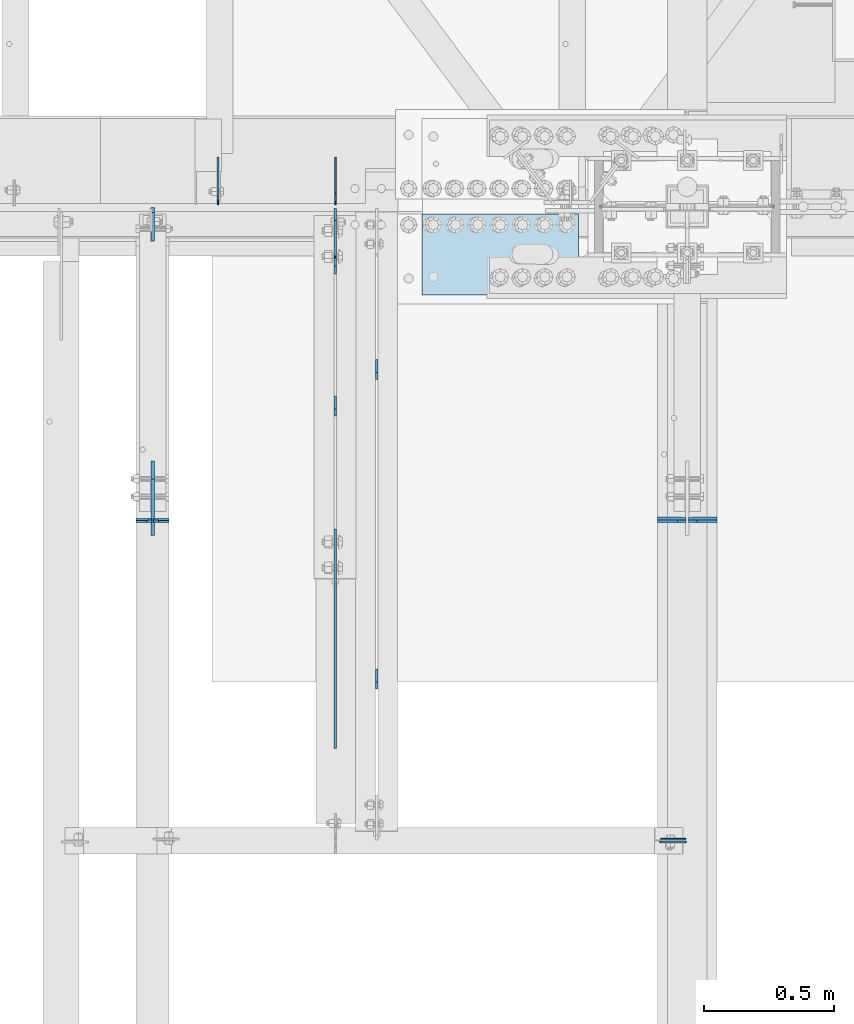
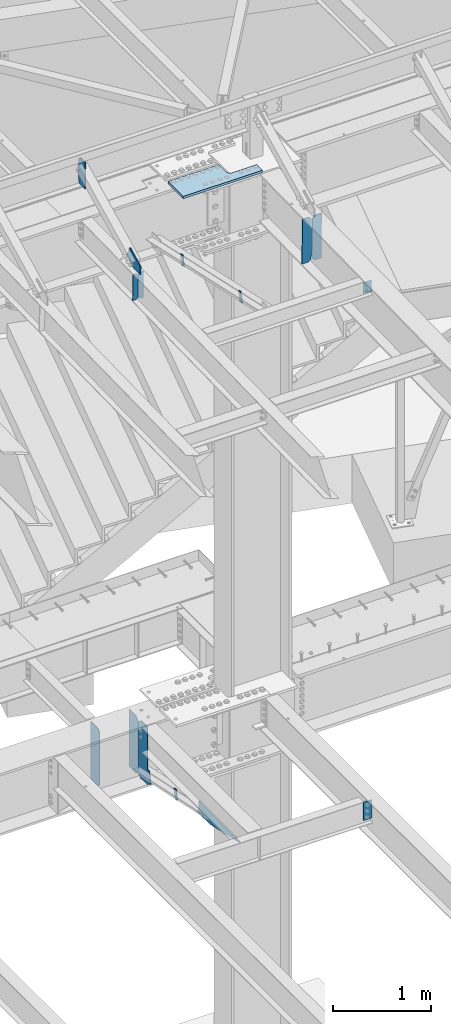
# One storey, part 1638 of 1763: 16 plates, 9 elements without a shape of their own.
"""IFC2X3 building model written with IfcOpenShell, lengths in millimetres."""

from ifc_helpers import new_model, si_unit, frame, origin_with_axes, place, context, subcontext, project, spatial, faceted_brep, material, type_object, element, aggregate, save


model = new_model("IFC2X3")

# Units and contexts
model_context = context("Model", 3, precision=1e-05, world=origin_with_axes())
body_context = subcontext(model_context, "Body", "Model", "MODEL_VIEW")
ifc_project = project(units=[si_unit("LENGTHUNIT", "METRE", prefix="MILLI"), si_unit("AREAUNIT", "SQUARE_METRE"), si_unit("VOLUMEUNIT", "CUBIC_METRE"), si_unit("MASSUNIT", "GRAM", prefix="KILO"), si_unit("TIMEUNIT", "SECOND"), si_unit("PLANEANGLEUNIT", "RADIAN"), si_unit("SOLIDANGLEUNIT", "STERADIAN"), si_unit("THERMODYNAMICTEMPERATUREUNIT", "DEGREE_CELSIUS"), si_unit("LUMINOUSINTENSITYUNIT", "LUMEN")], contexts=[model_context])

# Site, building, storey
site_placement = place(None, origin_with_axes())
site = spatial("IfcSite", under=ifc_project, at=site_placement, CompositionType="ELEMENT")
building_placement = place(site_placement, origin_with_axes())
building = spatial("IfcBuilding", under=site, at=building_placement, Name="Undefined", CompositionType="ELEMENT")
storey_placement = place(building_placement, origin_with_axes())
storey = spatial("IfcBuildingStorey", under=building, at=storey_placement, Name="Undefined", CompositionType="ELEMENT", Elevation=0.0)

# Assembly, plate
assembly_1_placement = place(storey_placement, origin_with_axes())
assembly_1 = element("IfcElementAssembly", 1, at=assembly_1_placement, inside=storey, Name="BEAM", AssemblyPlace="NOTDEFINED", PredefinedType="RIGID_FRAME")
ifc_material_1 = material(Name="STEEL/A36")
plate_type_1 = type_object("IfcPlateType", PredefinedType="NOTDEFINED")
plate_1_placement = place(assembly_1_placement, frame((-34955.3935236984, 49687.9562500283, 11646.2503374946), z_axis=(-1.0, 0.0, 0.0), x_axis=(0.0, 0.0, -1.0)))
plate_1 = element("IfcPlate", 2, at=plate_1_placement, type_object=plate_type_1, material=ifc_material_1, Name="PLATE", context=body_context, shape_type="Brep", body=[
    faceted_brep([(1.81898940354586e-12, -3.17500000000291, 0.0), (0.0, -3.17499999999927, 96.8375015258789), (0.0, 3.17499999999927, 96.8375015258789), (-1.81898940354586e-12, 3.17499999997381, 0.0), (139.699996948242, -3.17499999999927, 96.8375015258789), (139.699996948242, 3.17499999999927, 96.8375015258789), (139.699996948242, -3.17499999999927, 0.0), (139.699996948242, 3.17499999999927, 0.0)], [[[0, 1, 2, 3]], [[1, 4, 5, 2]], [[4, 6, 7, 5]], [[6, 0, 3, 7]], [[5, 7, 3, 2]], [[6, 4, 1, 0]]]),
])

assembly_2_placement = place(storey_placement, origin_with_axes())
assembly_2 = element("IfcElementAssembly", 3, at=assembly_2_placement, inside=storey, Name="BEAM", AssemblyPlace="NOTDEFINED", PredefinedType="RIGID_FRAME")
plate_type_2 = type_object("IfcPlateType", PredefinedType="NOTDEFINED")
plate_2_placement = place(assembly_2_placement, frame((-36303.9747736983, 50880.5595338104, 4883.15), z_axis=(0.0, -1.0, 0.0), x_axis=(0.0, 0.0, -1.0)))
plate_2 = element("IfcPlate", 4, at=plate_2_placement, type_object=plate_type_2, material=ifc_material_1, Name="PLATE", context=body_context, shape_type="Brep", body=[
    faceted_brep([(0.0, -4.76249999999982, 0.0), (0.0, -4.76249999999709, 844.603210449219), (0.0, 4.76249999999709, 844.603210449219), (0.0, 4.76249999999982, 0.0), (12.6999998092651, -4.76249999999709, 844.603210449219), (12.6999998092651, 4.76249999999709, 844.603210449219), (152.399993896484, -4.76249999999709, 235.00325012207), (152.399993896484, 4.76249999999709, 235.00325012207), (152.400009155272, -4.76249999948777, 5.45696821063757e-12), (152.400009155273, 4.76250000051368, 3.63797880709171e-12)], [[[0, 1, 2, 3]], [[1, 4, 5, 2]], [[4, 6, 7, 5]], [[6, 8, 9, 7]], [[8, 0, 3, 9]], [[5, 7, 9, 3, 2]], [[8, 6, 4, 1, 0]]]),
])
aggregate(assembly_2, [plate_2])

assembly_3_placement = place(storey_placement, origin_with_axes())
assembly_3 = element("IfcElementAssembly", 5, at=assembly_3_placement, inside=storey, Name="ANGLE BRACE", AssemblyPlace="NOTDEFINED", PredefinedType="RIGID_FRAME")
plate_type_3 = type_object("IfcPlateType", PredefinedType="NOTDEFINED")
plate_3_placement = place(assembly_3_placement, frame((-36303.9747736983, 51342.4281032895, 4746.91590772782), z_axis=(0.0, -0.208168683014592, -0.978092940068566), x_axis=(0.0, 0.978092940068566, -0.208168683014588)))
plate_3 = element("IfcPlate", 6, at=plate_3_placement, type_object=plate_type_3, material=ifc_material_1, Name="PLATE", context=body_context, shape_type="Brep", body=[
    faceted_brep([(0.0, -4.76249999999982, 0.0), (2.11002770811319e-09, -4.76249999999709, 127.040328979458), (2.11002770811319e-09, 4.76249999999709, 127.040328979458), (0.0, 4.76249999999982, 0.0), (50.7119293213109, -4.76249999999709, 126.999992370584), (50.7119293213109, 4.76249999999709, 126.999992370584), (50.7119293211581, -4.76249999999709, 1.63709046319127e-11), (50.7119293211581, 4.76249999999709, 1.63709046319127e-11)], [[[0, 1, 2, 3]], [[1, 4, 5, 2]], [[4, 6, 7, 5]], [[6, 0, 3, 7]], [[5, 7, 3, 2]], [[6, 4, 1, 0]]]),
])
aggregate(assembly_3, [plate_3])

# Assembly, plates
assembly_4_placement = place(storey_placement, origin_with_axes())
assembly_4 = element("IfcElementAssembly", 7, at=assembly_4_placement, inside=storey, Name="V. BRACE", AssemblyPlace="NOTDEFINED", PredefinedType="RIGID_FRAME")
plate_4_placement = place(assembly_4_placement, frame((-36144.6956070317, 51482.9306902405, 11287.086840155), z_axis=(0.0, -0.216256452978334, -0.976336594902204), x_axis=(0.0, 0.976336594902204, -0.216256452978331)))
plate_4 = element("IfcPlate", 8, at=plate_4_placement, type_object=plate_type_3, material=ifc_material_1, Name="PLATE", context=body_context, shape_type="Brep", body=[
    faceted_brep([(0.0, -4.76249999999982, 0.0), (-3.41970007866621e-10, -4.76249999999709, 127.083160400387), (-3.41970007866621e-10, 4.76249999999709, 127.083160400387), (0.0, 4.76249999999982, 0.0), (50.7957572936939, -4.76249999999709, 127.084861755386), (50.7957572936939, 4.76249999999709, 127.084861755386), (50.7999992370605, -4.76249999999709, 0.0), (50.7999992370605, 4.76249999999709, 0.0)], [[[0, 1, 2, 3]], [[1, 4, 5, 2]], [[4, 6, 7, 5]], [[6, 0, 3, 7]], [[5, 7, 3, 2]], [[6, 4, 1, 0]]]),
])
plate_5_placement = place(assembly_4_placement, frame((-36144.6956070317, 50292.5785804423, 11550.7352702641), z_axis=(0.0, -0.216256452978334, -0.976336594902204), x_axis=(0.0, 0.976336594902204, -0.216256452978331)))
plate_5 = element("IfcPlate", 9, at=plate_5_placement, type_object=plate_type_3, material=ifc_material_1, Name="PLATE", context=body_context, shape_type="Brep", body=[
    faceted_brep([(0.0, -4.76249999999982, 0.0), (-3.41970007866621e-10, -4.76249999999709, 127.083160400387), (-3.41970007866621e-10, 4.76249999999709, 127.083160400387), (0.0, 4.76249999999982, 0.0), (50.7957572936939, -4.76249999999709, 127.084861755386), (50.7957572936939, 4.76249999999709, 127.084861755386), (50.7999992370605, -4.76249999999709, 0.0), (50.7999992370605, 4.76249999999709, 0.0)], [[[0, 1, 2, 3]], [[1, 4, 5, 2]], [[4, 6, 7, 5]], [[6, 0, 3, 7]], [[5, 7, 3, 2]], [[6, 4, 1, 0]]]),
])
aggregate(assembly_4, [plate_4, plate_5])

assembly_5_placement = place(storey_placement, origin_with_axes())
assembly_5 = element("IfcElementAssembly", 10, at=assembly_5_placement, inside=storey, Name="BEAM", AssemblyPlace="NOTDEFINED", PredefinedType="RIGID_FRAME")
plate_type_4 = type_object("IfcPlateType", PredefinedType="NOTDEFINED")
plate_6_placement = place(assembly_5_placement, frame((-36942.5322886427, 50916.6522288945, 11382.7888861822), z_axis=(0.0, -0.0206852279954837, 0.999786037781472), x_axis=(-1.0, 0.0, 0.0)))
plate_6 = element("IfcPlate", 11, at=plate_6_placement, type_object=plate_type_4, material=ifc_material_1, Name="PLATE", context=body_context, shape_type="Brep", body=[
    faceted_brep([(0.0, -4.76249999999982, 0.0), (0.0, -4.7625000000844, 330.200012206782), (0.0, 4.76249999994616, 330.200012206786), (0.0, 4.76249999999982, 0.0), (41.2750015258789, -4.7625000000844, 330.200012206782), (41.2750015258789, 4.76249999994616, 330.200012206786), (60.3250007629395, -4.76250000007713, 311.150012969736), (60.3250007629395, 4.76249999994616, 311.15001296974), (60.3250007630195, -4.76250000009168, 19.0499992370605), (60.325000763034, 4.76249999992433, 19.0499992370605), (41.2750015259371, -4.76250000006985, 0.0), (41.2750015259444, 4.76249999995343, 0.0)], [[[0, 1, 2, 3]], [[1, 4, 5, 2]], [[4, 6, 7, 5]], [[6, 8, 9, 7]], [[8, 10, 11, 9]], [[10, 0, 3, 11]], [[5, 7, 9, 11, 3, 2]], [[10, 8, 6, 4, 1, 0]]]),
])
plate_7_placement = place(assembly_5_placement, frame((-37009.2072886427, 50916.6522288945, 11382.7888861822), z_axis=(0.0, -0.0206852279954837, 0.999786037781472), x_axis=(-1.0, 0.0, 0.0)))
plate_7 = element("IfcPlate", 12, at=plate_7_placement, type_object=plate_type_4, material=ifc_material_1, Name="PLATE", context=body_context, shape_type="Brep", body=[
    faceted_brep([(6.96272763889283e-08, -4.76249999999709, 19.0499992370605), (0.0, -4.76250000007713, 311.150012969736), (0.0, 4.76249999994616, 311.15001296974), (6.96454662829638e-08, 4.76249999999709, 19.0499992370605), (19.0499992370605, -4.7625000000844, 330.200012206782), (19.0499992370605, 4.76249999994616, 330.200012206786), (60.3250007629395, -4.7625000000844, 330.200012206782), (60.3250007629395, 4.76249999994616, 330.200012206786), (60.3250007629395, -4.76250000001892, 0.0), (60.3250007629395, 4.76250000001164, 1.81898940354586e-12), (19.0499992370533, -4.76249999996799, -2.09183781407773e-11), (19.0499992370678, 4.76250000003347, -2.09183781407773e-11)], [[[0, 1, 2, 3]], [[1, 4, 5, 2]], [[4, 6, 7, 5]], [[6, 8, 9, 7]], [[8, 10, 11, 9]], [[10, 0, 3, 11]], [[5, 7, 9, 11, 3, 2]], [[10, 8, 6, 4, 1, 0]]]),
])

# Assembly, plate
assembly_6_placement = place(storey_placement, origin_with_axes())
assembly_6 = element("IfcElementAssembly", 13, at=assembly_6_placement, inside=storey, Name="BEAM", AssemblyPlace="NOTDEFINED", PredefinedType="RIGID_FRAME")
plate_type_5 = type_object("IfcPlateType", PredefinedType="NOTDEFINED")
plate_8_placement = place(assembly_6_placement, frame((-34953.8060236984, 49676.84375, 5156.2), z_axis=(-1.0, 0.0, 0.0), x_axis=(0.0, 0.0, -1.0)))
plate_8 = element("IfcPlate", 14, at=plate_8_placement, type_object=plate_type_5, material=ifc_material_1, Name="PLATE", context=body_context, shape_type="Brep", body=[
    faceted_brep([(1.81898940354586e-12, -3.17500000000291, 0.0), (0.0, -3.17499999999927, 101.599998474121), (0.0, 3.17499999999927, 101.599998474121), (-1.81898940354586e-12, 3.17499999997381, 0.0), (228.600006103516, -3.17499999999927, 101.599998474121), (228.600006103516, 3.17499999999927, 101.599998474121), (228.600006103516, -3.17500000001019, -7.27595761418343e-12), (228.600006103516, 3.17499999999563, -7.27595761418343e-12)], [[[0, 1, 2, 3]], [[1, 4, 5, 2]], [[4, 6, 7, 5]], [[6, 0, 3, 7]], [[5, 7, 3, 2]], [[6, 4, 1, 0]]]),
])
aggregate(assembly_6, [plate_8])

# Plate
plate_type_6 = type_object("IfcPlateType", PredefinedType="NOTDEFINED")
plate_9_placement = place(assembly_1_placement, frame((-34835.5372736983, 50921.743559647, 11135.1912249708), z_axis=(0.0, -0.0206852279954837, 0.999786037781472), x_axis=(-1.0, 0.0, 0.0)))
plate_9 = element("IfcPlate", 15, at=plate_9_placement, type_object=plate_type_6, material=ifc_material_1, Name="PLATE", context=body_context, shape_type="Brep", body=[
    faceted_brep([(0.0, -4.76249999999982, 0.0), (0.0, -4.76250000012806, 568.325012206604), (0.0, 4.7624999999025, 568.325012206606), (0.0, 4.76249999999982, 0.0), (76.9937515258789, -4.76250000012806, 568.325012206604), (76.9937515258789, 4.7624999999025, 568.325012206606), (108.743751525879, -4.76250000012078, 536.575012206626), (108.743751525879, 4.76249999990978, 536.575012206629), (108.743751525879, -4.76250000001892, 31.7499999999764), (108.743751525879, 4.76250000000437, 31.7499999999782), (76.9937515258789, -4.76250000001892, -1.81898940354586e-12), (76.9937515258789, 4.76250000001164, 3.63797880709171e-12)], [[[0, 1, 2, 3]], [[1, 4, 5, 2]], [[4, 6, 7, 5]], [[6, 8, 9, 7]], [[8, 10, 11, 9]], [[10, 0, 3, 11]], [[5, 7, 9, 11, 3, 2]], [[10, 8, 6, 4, 1, 0]]]),
])

plate_10_placement = place(assembly_1_placement, frame((-34955.3935236984, 50921.743559647, 11135.1912249708), z_axis=(0.0, -0.0206852279954837, 0.999786037781472), x_axis=(-1.0, 0.0, 0.0)))
plate_10 = element("IfcPlate", 16, at=plate_10_placement, type_object=plate_type_6, material=ifc_material_1, Name="PLATE", context=body_context, shape_type="Brep", body=[
    faceted_brep([(0.0, -4.76250000000073, 31.75), (0.0, -4.76250000012078, 536.575012206626), (0.0, 4.76249999990978, 536.575012206629), (0.0, 4.76250000000073, 31.75), (31.75, -4.76250000012806, 568.325012206604), (31.75, 4.7624999999025, 568.325012206606), (108.743751525879, -4.76250000012806, 568.325012206604), (108.743751525879, 4.7624999999025, 568.325012206606), (108.743751525879, -4.76250000001892, -1.81898940354586e-12), (108.743751525879, 4.76250000001164, 3.63797880709171e-12), (31.75, -4.76250000000073, 0.0), (31.75, 4.76250000000073, 0.0)], [[[0, 1, 2, 3]], [[1, 4, 5, 2]], [[4, 6, 7, 5]], [[6, 8, 9, 7]], [[8, 10, 11, 9]], [[10, 0, 3, 11]], [[5, 7, 9, 11, 3, 2]], [[10, 8, 6, 4, 1, 0]]]),
])

aggregate(assembly_1, [plate_9, plate_10, plate_1])

plate_type_7 = type_object("IfcPlateType", PredefinedType="NOTDEFINED")
plate_11_placement = place(assembly_5_placement, frame((-37006.0322886427, 50858.8358090945, 11721.390388285), z_axis=(0.0, -0.0206852279954837, 0.999786037781472), x_axis=(0.0, 0.999786037781472, 0.0206852279954825)))
plate_11 = element("IfcPlate", 17, at=plate_11_placement, type_object=plate_type_7, material=ifc_material_1, Name="PLATE", context=body_context, shape_type="Brep", body=[
    faceted_brep([(0.0, -6.34999999999491, 1.45519152283669e-11), (1.45519152283669e-11, -6.34999999999854, 101.599998474047), (1.45519152283669e-11, 6.34999999999854, 101.599998474047), (0.0, 6.34999999999491, -2.91038304567337e-11), (218.951583862981, -6.34999999999854, 205.463943481234), (218.951583862981, 6.34999999999854, 205.463943481234), (284.27273559654, -6.34999999999854, 67.7725906370797), (284.27273559654, 6.34999999999854, 67.7725906370797), (141.413955688891, -6.34999999999854, -4.72937244921923e-11), (141.413955688891, 6.34999999999854, -4.72937244921923e-11)], [[[0, 1, 2, 3]], [[1, 4, 5, 2]], [[4, 6, 7, 5]], [[6, 8, 9, 7]], [[8, 0, 3, 9]], [[5, 7, 9, 3, 2]], [[8, 6, 4, 1, 0]]]),
])

aggregate(assembly_5, [plate_6, plate_7, plate_11])

# Assembly, plate
assembly_7_placement = place(storey_placement, origin_with_axes())
assembly_7 = element("IfcElementAssembly", 18, at=assembly_7_placement, inside=storey, Name="BEAM", AssemblyPlace="NOTDEFINED", PredefinedType="RIGID_FRAME")
plate_type_8 = type_object("IfcPlateType", PredefinedType="NOTDEFINED")
plate_12_placement = place(assembly_7_placement, frame((-37006.0322886427, 51990.6249997282, 12106.275), z_axis=(0.0, 0.0, 1.0), x_axis=(0.0, 1.0, 0.0)))
plate_12 = element("IfcPlate", 19, at=plate_12_placement, type_object=plate_type_8, material=ifc_material_1, Name="PLATE", context=body_context, shape_type="Brep", body=[
    faceted_brep([(0.0, -6.34999999999491, 1.45519152283669e-11), (0.0, -6.34999999999854, 330.200012207031), (0.0, 6.34999999999854, 330.200012207031), (0.0, 6.34999999999491, -2.91038304567337e-11), (107.950000762939, -6.34999999999854, 330.200012207031), (107.950000762939, 6.34999999999854, 330.200012207031), (127.0, -6.34999999999854, 311.150012969971), (127.0, 6.34999999999854, 311.150012969971), (127.0, -6.34999999999854, 19.0499992370605), (127.0, 6.34999999999854, 19.0499992370605), (107.950000762939, -6.34999999999854, 0.0), (107.950000762939, 6.34999999999854, 0.0)], [[[0, 1, 2, 3]], [[1, 4, 5, 2]], [[4, 6, 7, 5]], [[6, 8, 9, 7]], [[8, 10, 11, 9]], [[10, 0, 3, 11]], [[5, 7, 9, 11, 3, 2]], [[10, 8, 6, 4, 1, 0]]]),
])
aggregate(assembly_7, [plate_12])

# Assembly, plates
assembly_8_placement = place(storey_placement, origin_with_axes())
assembly_8 = element("IfcElementAssembly", 20, at=assembly_8_placement, inside=storey, Name="BEAM", AssemblyPlace="NOTDEFINED", PredefinedType="RIGID_FRAME")
plate_type_9 = type_object("IfcPlateType", PredefinedType="NOTDEFINED")
plate_13_placement = place(assembly_8_placement, frame((-36754.7586274127, 52128.7375, 4448.175), z_axis=(0.0, 0.0, 1.0), x_axis=(0.0, 1.0, 0.0)))
plate_13 = element("IfcPlate", 21, at=plate_13_placement, type_object=plate_type_9, material=ifc_material_1, Name="PLATE", context=body_context, shape_type="Brep", body=[
    faceted_brep([(0.0, -3.17500000000291, 31.75), (0.0, -3.17500000000291, 687.387512207031), (0.0, 3.17500000000291, 687.387512207031), (0.0, 3.17500000000291, 31.75), (31.75, -3.17500000000291, 719.137512207031), (31.75, 3.17500000000291, 719.137512207031), (182.5625, -3.17500000000291, 719.137512207031), (182.5625, 3.17500000000291, 719.137512207031), (182.5625, -3.17500000000291, 0.0), (182.5625, 3.17500000000291, 0.0), (31.7499999999036, -3.17499999997381, 9.42916855706244e-11), (31.7499999998854, 3.17500000000291, 9.42916855706244e-11)], [[[0, 1, 2, 3]], [[1, 4, 5, 2]], [[4, 6, 7, 5]], [[6, 8, 9, 7]], [[8, 10, 11, 9]], [[10, 0, 3, 11]], [[5, 7, 9, 11, 3, 2]], [[10, 8, 6, 4, 1, 0]]]),
])
plate_14_placement = place(assembly_8_placement, frame((-36302.387273746, 52128.7375, 4448.175), z_axis=(0.0, 0.0, 1.0), x_axis=(0.0, 1.0, 0.0)))
plate_14 = element("IfcPlate", 22, at=plate_14_placement, type_object=plate_type_9, material=ifc_material_1, Name="PLATE", context=body_context, shape_type="Brep", body=[
    faceted_brep([(0.0, -3.17500000000291, 44.4500000000007), (0.0, -3.17500000000291, 673.099987030029), (0.0, 3.17500000000291, 673.099987030029), (0.0, 3.17500000000291, 44.4500000000007), (44.4500007629395, -3.17500000000291, 717.549987792969), (44.4500007629395, 3.17500000000291, 717.549987792969), (182.5625, -3.17500000000291, 717.549987792969), (182.5625, 3.17500000000291, 717.549987792969), (182.5625, -3.17500000000291, 0.0), (182.5625, 3.17500000000291, 0.0), (44.4500007629395, -3.17500000000291, 0.0), (44.4500007629395, 3.17500000000291, 0.0)], [[[0, 1, 2, 3]], [[1, 4, 5, 2]], [[4, 6, 7, 5]], [[6, 8, 9, 7]], [[8, 10, 11, 9]], [[10, 0, 3, 11]], [[5, 7, 9, 11, 3, 2]], [[10, 8, 6, 4, 1, 0]]]),
])

# Assembly, plate
assembly_9_placement = place(storey_placement, origin_with_axes())
assembly_9 = element("IfcElementAssembly", 23, at=assembly_9_placement, inside=storey, Name="TOP PLATE", AssemblyPlace="NOTDEFINED", PredefinedType="RIGID_FRAME")
ifc_material_2 = material(Name="STEEL/A572-50")
plate_type_10 = type_object("IfcPlateType", PredefinedType="NOTDEFINED")
plate_15_placement = place(assembly_9_placement, frame((-35367.3497736984, 52092.2250002128, 11761.7874917654), z_axis=(0.0, -1.0, 0.0), x_axis=(-1.0, 0.0, 0.0)))
plate_15 = element("IfcPlate", 24, at=plate_15_placement, type_object=plate_type_10, material=ifc_material_2, Name="TOP PLATE", context=body_context, shape_type="Brep", body=[
    faceted_brep([(0.0, -14.2875000000058, 0.0), (0.0, -14.2875000000004, 152.400001525879), (0.0, 14.2875000000004, 152.400001525879), (0.0, 14.2875000000058, 0.0), (-3.14187241174659, -14.2875000000004, 168.195260780674), (-3.14187241174659, 14.2875000000004, 168.195260780674), (-12.0891680534478, -14.2875000000004, 181.58583499831), (-12.0891680534478, 14.2875000000004, 181.58583499831), (-25.4797422710835, -14.2875000000004, 190.533130640011), (-25.4797422710835, 14.2875000000004, 190.533130640011), (-41.2750015258789, -14.2875000000004, 193.675003051758), (-41.2750015258789, 14.2875000000004, 193.675003051758), (-336.549987792969, -14.2875000000004, 193.675003051758), (-336.549987792969, 14.2875000000004, 193.675003051758), (-336.549987792969, -14.2875000000004, 311.149993896484), (-336.549987792969, 14.2875000000004, 311.149993896484), (603.25, -14.2875000000004, 311.149993896484), (603.25, 14.2875000000004, 311.149993896484), (603.25, -14.2875000000004, 0.0), (603.25, 14.2875000000004, 0.0)], [[[0, 1, 2, 3]], [[1, 4, 5, 2]], [[4, 6, 7, 5]], [[6, 8, 9, 7]], [[8, 10, 11, 9]], [[10, 12, 13, 11]], [[12, 14, 15, 13]], [[14, 16, 17, 15]], [[16, 18, 19, 17]], [[18, 0, 3, 19]], [[5, 7, 9, 11, 13, 15, 17, 19, 3, 2]], [[18, 16, 14, 12, 10, 8, 6, 4, 1, 0]]]),
])
aggregate(assembly_9, [plate_15])

# Plate
plate_type_11 = type_object("IfcPlateType", PredefinedType="NOTDEFINED")
plate_16_placement = place(assembly_8_placement, frame((-36303.974773746, 52112.8625, 4448.175), z_axis=(0.0, 0.0, 1.0), x_axis=(0.0, -1.0, 0.0)))
plate_16 = element("IfcPlate", 25, at=plate_16_placement, type_object=plate_type_11, material=ifc_material_1, Name="PLATE", context=body_context, shape_type="Brep", body=[
    faceted_brep([(-8.03411239758134e-08, -4.76249999999709, 44.4500007629395), (-1.21945049613714e-06, -4.76249999999709, 674.687450408936), (-1.21945049613714e-06, 4.76249999999709, 674.687450408936), (-8.03411239758134e-08, 4.76249999999709, 44.4500007629395), (44.4499994631478, -4.76249999999709, 719.137436311141), (44.4499994631478, 4.76249999999709, 719.137436311141), (182.5625, -4.76249999999709, 719.137390136719), (182.5625, 4.76249999999709, 719.137390136719), (182.5625, -4.76249999999709, 201.622897148132), (182.5625, 4.76249999999709, 201.622897148132), (183.529229922591, -4.76249999999709, 196.762817630087), (183.529229922591, 4.76249999999709, 196.762817630087), (186.282243823065, -4.76249999999709, 192.642641161933), (186.282243823065, 4.76249999999709, 192.642641161933), (190.402420291219, -4.76249999999709, 189.889627261455), (190.402420291219, 4.76249999999709, 189.889627261455), (195.262499809265, -4.76249999999709, 188.922897338867), (195.262499809265, 4.76249999999709, 188.922897338867), (219.799514770508, -4.76249999999709, 188.922897338867), (219.799514770508, 4.76249999999709, 188.922897338867), (250.737014770508, -4.76249999999709, 42.4546127319336), (250.737014770508, 4.76249999999709, 42.4546127319336), (182.5625, -4.76249999999709, -3.63797880709171e-12), (182.5625, 4.76249999999709, -3.63797880709171e-12), (44.4500007629395, -4.76249999999709, 0.0), (44.4500007629395, 4.76249999999709, 0.0)], [[[0, 1, 2, 3]], [[1, 4, 5, 2]], [[4, 6, 7, 5]], [[6, 8, 9, 7]], [[8, 10, 11, 9]], [[10, 12, 13, 11]], [[12, 14, 15, 13]], [[14, 16, 17, 15]], [[16, 18, 19, 17]], [[18, 20, 21, 19]], [[20, 22, 23, 21]], [[22, 24, 25, 23]], [[24, 0, 3, 25]], [[5, 7, 9, 11, 13, 15, 17, 19, 21, 23, 25, 3, 2]], [[24, 22, 20, 18, 16, 14, 12, 10, 8, 6, 4, 1, 0]]]),
])

aggregate(assembly_8, [plate_13, plate_14, plate_16])

save(model, "model.ifc")
